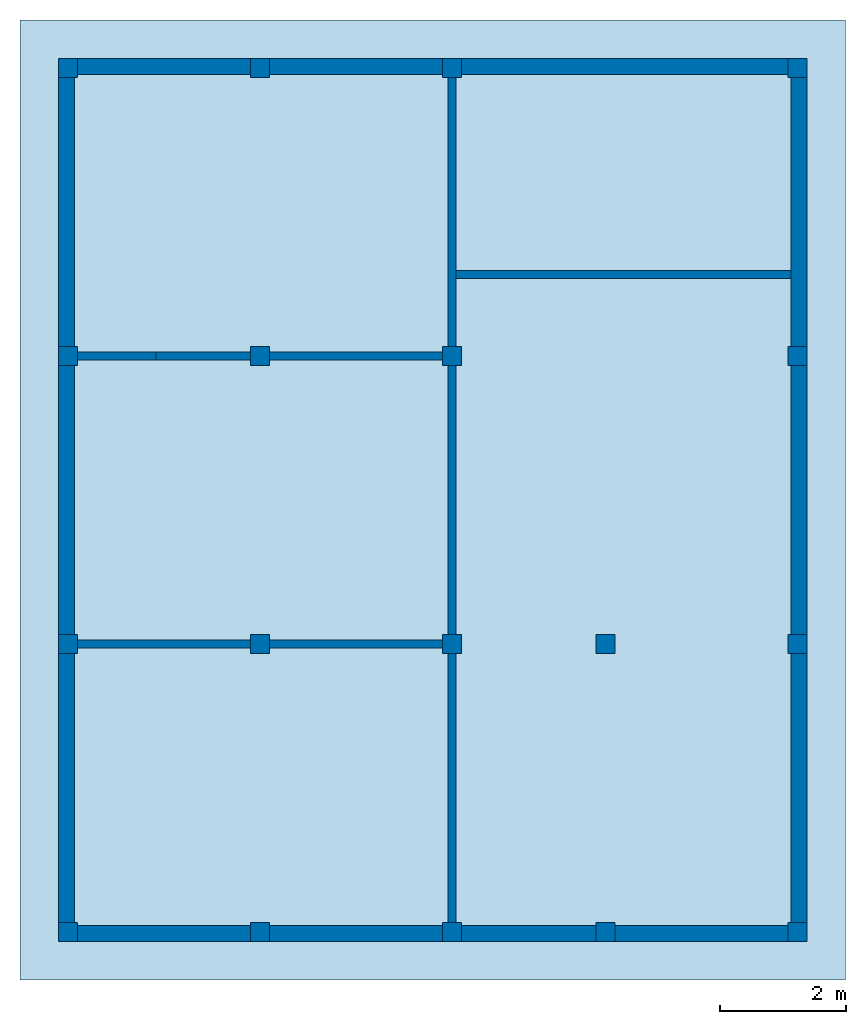
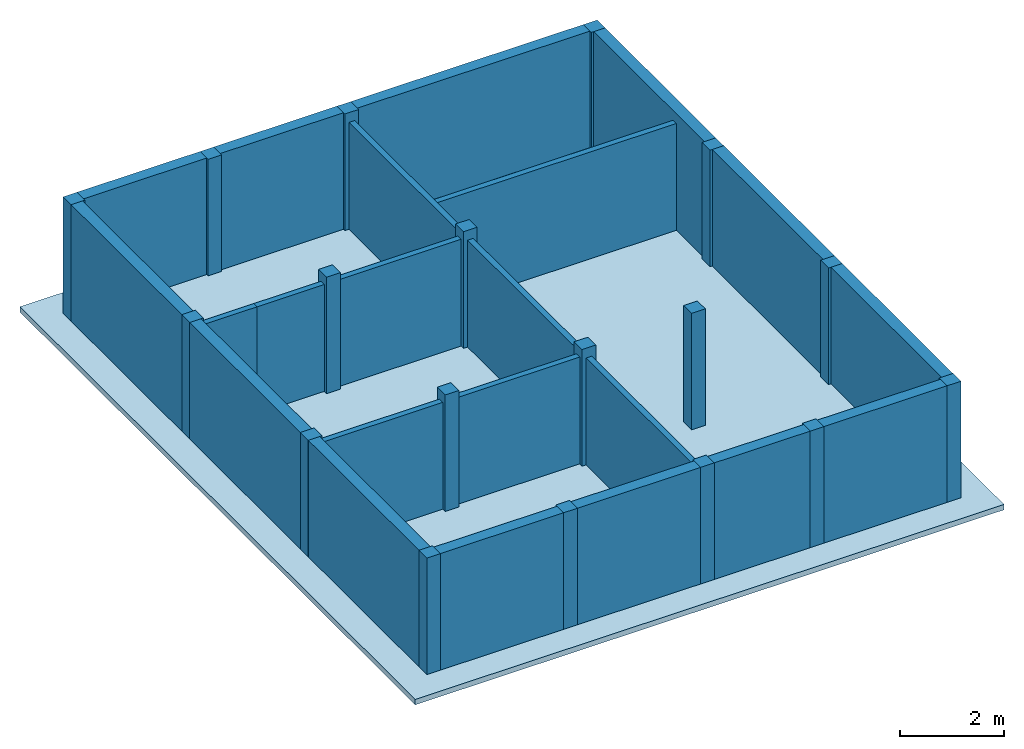
# One storey: 18 columns, 12 walls, 1 slab.
"""IFC2X3 building model written with IfcOpenShell, lengths in feet."""

from ifc_helpers import new_model, entity, si_unit, converted_unit, derived_unit, direction, frame, frame_2d, origin, origin_2d_with_axis, place, context, subcontext, project, spatial, rectangle, extrude, source, transform, mapped, material, layer, layer_set, layer_usage, type_object, type_shapes, element, save


model = new_model("IFC2X3")

# Units and contexts
model_context = context("Model", 3, precision=0.0001, world=origin(), true_north=direction((6.123031769111886e-17, 1.0)))
body_context = subcontext(model_context, "Body", "Model", "MODEL_VIEW")
ifc_project = project(units=[converted_unit("LENGTHUNIT", "FOOT", entity("IfcLengthMeasure", 0.3048), si_unit("LENGTHUNIT", "METRE"), dimensions=[1, 0, 0, 0, 0, 0, 0]), converted_unit("AREAUNIT", "SQUARE FOOT", entity("IfcAreaMeasure", 0.09290304), si_unit("AREAUNIT", "SQUARE_METRE"), dimensions=[2, 0, 0, 0, 0, 0, 0]), converted_unit("VOLUMEUNIT", "CUBIC FOOT", entity("IfcVolumeMeasure", 0.028316846592000004), si_unit("VOLUMEUNIT", "CUBIC_METRE"), dimensions=[3, 0, 0, 0, 0, 0, 0]), converted_unit("PLANEANGLEUNIT", "DEGREE", entity("IfcPlaneAngleMeasure", 0.017453292519943278), si_unit("PLANEANGLEUNIT", "RADIAN"), dimensions=[0, 0, 0, 0, 0, 0, 0]), si_unit("MASSUNIT", "GRAM", prefix="KILO"), derived_unit("MASSDENSITYUNIT", [(si_unit("MASSUNIT", "GRAM", prefix="KILO"), 1), (si_unit("LENGTHUNIT", "METRE"), -3)]), derived_unit("IONCONCENTRATIONUNIT", [(si_unit("MASSUNIT", "GRAM", prefix="KILO"), 1), (si_unit("LENGTHUNIT", "METRE"), -3)]), derived_unit("MOMENTOFINERTIAUNIT", [(si_unit("LENGTHUNIT", "METRE"), 4)]), si_unit("TIMEUNIT", "SECOND"), si_unit("FREQUENCYUNIT", "HERTZ"), si_unit("THERMODYNAMICTEMPERATUREUNIT", "DEGREE_CELSIUS"), derived_unit("THERMALTRANSMITTANCEUNIT", [(si_unit("MASSUNIT", "GRAM", prefix="KILO"), 1), (si_unit("THERMODYNAMICTEMPERATUREUNIT", "KELVIN"), -1), (si_unit("TIMEUNIT", "SECOND"), -3)]), derived_unit("THERMALCONDUCTANCEUNIT", [(si_unit("MASSUNIT", "GRAM", prefix="KILO"), 1), (si_unit("THERMODYNAMICTEMPERATUREUNIT", "KELVIN"), -1), (si_unit("TIMEUNIT", "SECOND"), -3), (si_unit("LENGTHUNIT", "METRE"), 1)]), derived_unit("VOLUMETRICFLOWRATEUNIT", [(si_unit("LENGTHUNIT", "METRE"), 3), (si_unit("TIMEUNIT", "SECOND"), -1)]), derived_unit("MASSFLOWRATEUNIT", [(si_unit("MASSUNIT", "GRAM", prefix="KILO"), 1), (si_unit("TIMEUNIT", "SECOND"), -1)]), derived_unit("ROTATIONALFREQUENCYUNIT", [(si_unit("TIMEUNIT", "SECOND"), -1)]), si_unit("ELECTRICCURRENTUNIT", "AMPERE"), si_unit("ELECTRICVOLTAGEUNIT", "VOLT"), si_unit("POWERUNIT", "WATT"), converted_unit("FORCEUNIT", "KIP", entity("IfcForceMeasure", 2.088543423315013e-05), si_unit("FORCEUNIT", "NEWTON"), dimensions=[1, 1, -2, 0, 0, 0, 0]), si_unit("ILLUMINANCEUNIT", "LUX"), si_unit("LUMINOUSFLUXUNIT", "LUMEN"), si_unit("LUMINOUSINTENSITYUNIT", "CANDELA"), si_unit("ENERGYUNIT", "JOULE"), derived_unit("USERDEFINED", [(si_unit("MASSUNIT", "GRAM", prefix="KILO"), -1), (si_unit("LENGTHUNIT", "METRE"), -2), (si_unit("TIMEUNIT", "SECOND"), 3), (si_unit("LUMINOUSFLUXUNIT", "LUMEN"), 1)]), derived_unit("USERDEFINED", [(si_unit("MASSUNIT", "GRAM", prefix="KILO"), 1), (si_unit("TIMEUNIT", "SECOND"), -3), (si_unit("LENGTHUNIT", "METRE"), 3), (si_unit("ELECTRICCURRENTUNIT", "AMPERE"), -2)]), derived_unit("SOUNDPOWERUNIT", [(si_unit("MASSUNIT", "GRAM", prefix="KILO"), 1), (si_unit("TIMEUNIT", "SECOND"), -3), (si_unit("LENGTHUNIT", "METRE"), 2)]), derived_unit("SOUNDPRESSUREUNIT", [(si_unit("MASSUNIT", "GRAM", prefix="KILO"), 1), (si_unit("LENGTHUNIT", "METRE"), -1), (si_unit("TIMEUNIT", "SECOND"), -2)]), derived_unit("LINEARVELOCITYUNIT", [(si_unit("LENGTHUNIT", "METRE"), 1), (si_unit("TIMEUNIT", "SECOND"), -1)]), si_unit("PRESSUREUNIT", "PASCAL"), derived_unit("USERDEFINED", [(si_unit("MASSUNIT", "GRAM", prefix="KILO"), 1), (si_unit("LENGTHUNIT", "METRE"), -2), (si_unit("TIMEUNIT", "SECOND"), -2)]), derived_unit("LINEARFORCEUNIT", [(si_unit("MASSUNIT", "GRAM", prefix="KILO"), 1), (si_unit("TIMEUNIT", "SECOND"), -2)]), derived_unit("PLANARFORCEUNIT", [(si_unit("MASSUNIT", "GRAM", prefix="KILO"), 1), (si_unit("LENGTHUNIT", "METRE"), -1), (si_unit("TIMEUNIT", "SECOND"), -2)]), derived_unit("SPECIFICHEATCAPACITYUNIT", [(si_unit("THERMODYNAMICTEMPERATUREUNIT", "KELVIN"), -1), (si_unit("LENGTHUNIT", "METRE"), 2), (si_unit("TIMEUNIT", "SECOND"), -2)]), derived_unit("HEATFLUXDENSITYUNIT", [(si_unit("MASSUNIT", "GRAM", prefix="KILO"), 1), (si_unit("TIMEUNIT", "SECOND"), -3)]), derived_unit("HEATINGVALUEUNIT", [(si_unit("LENGTHUNIT", "METRE"), 2), (si_unit("TIMEUNIT", "SECOND"), -2)]), derived_unit("VAPORPERMEABILITYUNIT", [(si_unit("LENGTHUNIT", "METRE"), -1), (si_unit("TIMEUNIT", "SECOND"), 1)]), derived_unit("DYNAMICVISCOSITYUNIT", [(si_unit("MASSUNIT", "GRAM", prefix="KILO"), 1), (si_unit("TIMEUNIT", "SECOND"), -1), (si_unit("LENGTHUNIT", "METRE"), -1)]), derived_unit("THERMALEXPANSIONCOEFFICIENTUNIT", [(si_unit("THERMODYNAMICTEMPERATUREUNIT", "KELVIN"), -1)]), derived_unit("MODULUSOFELASTICITYUNIT", [(si_unit("MASSUNIT", "GRAM", prefix="KILO"), 1), (si_unit("LENGTHUNIT", "METRE"), -1), (si_unit("TIMEUNIT", "SECOND"), -2)]), derived_unit("ISOTHERMALMOISTURECAPACITYUNIT", [(si_unit("LENGTHUNIT", "METRE"), 3), (si_unit("MASSUNIT", "GRAM", prefix="KILO"), -1)]), derived_unit("MOISTUREDIFFUSIVITYUNIT", [(si_unit("TIMEUNIT", "SECOND"), -1), (si_unit("LENGTHUNIT", "METRE"), 2)]), derived_unit("MASSPERLENGTHUNIT", [(si_unit("MASSUNIT", "GRAM", prefix="KILO"), 1), (si_unit("LENGTHUNIT", "METRE"), -1)]), derived_unit("THERMALRESISTANCEUNIT", [(si_unit("MASSUNIT", "GRAM", prefix="KILO"), -1), (si_unit("TIMEUNIT", "SECOND"), 3), (si_unit("THERMODYNAMICTEMPERATUREUNIT", "KELVIN"), 1)]), derived_unit("ACCELERATIONUNIT", [(si_unit("LENGTHUNIT", "METRE"), 1), (si_unit("TIMEUNIT", "SECOND"), -2)]), derived_unit("ANGULARVELOCITYUNIT", [(si_unit("TIMEUNIT", "SECOND"), -1), (si_unit("PLANEANGLEUNIT", "RADIAN"), 1)]), derived_unit("LINEARSTIFFNESSUNIT", [(si_unit("MASSUNIT", "GRAM", prefix="KILO"), 1), (si_unit("TIMEUNIT", "SECOND"), -2)]), derived_unit("WARPINGCONSTANTUNIT", [(si_unit("LENGTHUNIT", "METRE"), 6)]), derived_unit("LINEARMOMENTUNIT", [(si_unit("MASSUNIT", "GRAM", prefix="KILO"), 1), (si_unit("LENGTHUNIT", "METRE"), 1), (si_unit("TIMEUNIT", "SECOND"), -2)]), derived_unit("TORQUEUNIT", [(si_unit("MASSUNIT", "GRAM", prefix="KILO"), 1), (si_unit("LENGTHUNIT", "METRE"), 2), (si_unit("TIMEUNIT", "SECOND"), -2)])], contexts=[model_context])

# Site, building, storey
site_placement = place(None, origin())
site = spatial("IfcSite", under=ifc_project, at=site_placement, CompositionType="ELEMENT")
building_placement = place(site_placement, origin())
building = spatial("IfcBuilding", under=site, at=building_placement, CompositionType="ELEMENT")
storey_placement = place(building_placement, frame((0.0, 0.0, 18.833333333333574)))
storey = spatial("IfcBuildingStorey", under=building, at=storey_placement, Name="Second Floor", CompositionType="ELEMENT", Elevation=18.833333333333574)

# Columns
ifc_material_1 = material(Name="Concrete, Cast-in-Place gray")
column_type = type_object("IfcColumnType", PredefinedType="COLUMN", material=ifc_material_1)
shared_shape = source(origin(), body_context, "Body", "SweptSolid", [
    extrude(rectangle(XDim=0.9999999999999999, YDim=0.9999999999999999, at=origin_2d_with_axis()), frame((0.0, 0.0, 18.833333333333574), z_axis=(0.0, 0.0, 1.0), x_axis=(-1.0, 0.0, 0.0)), (0.0, 0.0, 1.0), 9.00000000000162),
])
type_shapes(column_type, [shared_shape])
for number, where in (
    (1, (9.874478019162162, -49.84124484724893, -18.833333333333574)),
    (2, (29.874478019162154, -49.841244847248994, -18.833333333333574)),
    (3, (37.87447801916216, -49.84124484724902, -18.833333333333574)),
    (4, (47.87447801916217, -49.84124484724906, -18.833333333333574)),
    (5, (19.874478019162158, -49.841244847248966, -18.833333333333574)),
    (6, (9.874478019162186, -34.84124484724893, -18.833333333333574)),
    (7, (29.87447801916219, -34.841244847248994, -18.833333333333574)),
    (8, (37.87447801916219, -34.84124484724902, -18.833333333333574)),
    (9, (47.87447801916219, -34.84124484724906, -18.833333333333574)),
    (10, (19.874478019162183, -34.841244847248966, -18.833333333333574)),
    (11, (9.874478019162211, -19.841244847248934, -18.833333333333574)),
    (12, (29.87447801916221, -19.841244847248998, -18.833333333333574)),
    (13, (47.87447801916221, -19.841244847249058, -18.833333333333574)),
    (14, (19.874478019162204, -19.841244847248966, -18.833333333333574)),
    (15, (9.874478019162234, -4.841244847248884, -18.833333333333574)),
    (16, (29.874478019162233, -4.841244847248948, -18.833333333333574)),
    (17, (47.87447801916224, -4.841244847249006, -18.833333333333574)),
    (18, (19.87447801916223, -4.841244847248915, -18.833333333333574)),
):
    element("IfcColumn", number, at=place(storey_placement, frame(where)), inside=storey, type_object=column_type, material=ifc_material_1, context=body_context, shape_type="MappedRepresentation", body=[
        mapped(shared_shape, transform((0.0, 0.0, 0.0), scale=1.0)),
    ])

# Slab
ifc_material_2 = material(Name="Default Floor")
ifc_layer_1 = layer(ifc_material_2, 0.4166666666666667)
ifc_layer_set_1 = layer_set([ifc_layer_1])
ifc_layer_usage_1 = layer_usage(ifc_layer_set_1, "AXIS3", "POSITIVE", 0.0)
slab_type = type_object("IfcSlabType", PredefinedType="FLOOR", material=ifc_layer_set_1)
slab_placement = place(storey_placement, origin())
element("IfcSlab", 19, at=slab_placement, inside=storey, type_object=slab_type, material=ifc_layer_usage_1, PredefinedType="FLOOR", context=body_context, shape_type="SweptSolid", body=[
    extrude(rectangle(XDim=50.00000000000018, YDim=42.99999999999993, at=origin_2d_with_axis()), frame((28.874478019162204, -27.34124484724897, 0.0), z_axis=(0.0, 0.0, -1.0), x_axis=(0.0, 1.0, 0.0)), (0.0, 0.0, 1.0), 0.41666666666666785),
])

# Walls
ifc_material_3 = material(Name="Pink Paint")
ifc_layer_2 = layer(ifc_material_3, 0.041666666666666664)
ifc_material_4 = material(Name="Default Wall")
ifc_layer_3 = layer(ifc_material_4, 0.75)
ifc_material_5 = material(Name="Gypsum Wall Board")
ifc_layer_4 = layer(ifc_material_5, 0.041666666666666664)
ifc_layer_set_2 = layer_set([ifc_layer_2, ifc_layer_3, ifc_layer_4])
ifc_layer_usage_2 = layer_usage(ifc_layer_set_2, "AXIS2", "NEGATIVE", 0.4166666666666667)
wall_type_1 = type_object("IfcWallType", PredefinedType="STANDARD", material=ifc_layer_set_2)
wall_1_placement = place(storey_placement, frame((9.374478019162236, -4.757911513915549, 0.0)))
element("IfcWallStandardCase", 20, at=wall_1_placement, inside=storey, type_object=wall_type_1, material=ifc_layer_usage_2, context=body_context, shape_type="SweptSolid", body=[
    extrude(rectangle(XDim=38.1666666666666, YDim=0.8333333333333339, at=frame_2d((19.0833333333333, 0.0), x_axis=(-1.0, 0.0))), origin(), (0.0, 0.0, 1.0), 9.00000000000162),
])
wall_2_placement = place(storey_placement, frame((9.791144685828902, -50.34124484724887, 0.0), z_axis=(0.0, 0.0, 1.0), x_axis=(0.0, 1.0, 0.0)))
element("IfcWallStandardCase", 21, at=wall_2_placement, inside=storey, type_object=wall_type_1, material=ifc_layer_usage_2, context=body_context, shape_type="SweptSolid", body=[
    extrude(rectangle(XDim=45.16666666666666, YDim=0.8333333333333321, at=frame_2d((22.58333333333333, 0.0), x_axis=(-1.0, 0.0))), origin(), (0.0, 0.0, 1.0), 9.00000000000162),
])
wall_3_placement = place(storey_placement, frame((48.37447801916217, -49.924578180582216, 0.0), z_axis=(0.0, 0.0, 1.0), x_axis=(-1.0, 0.0, 0.0)))
element("IfcWallStandardCase", 22, at=wall_3_placement, inside=storey, type_object=wall_type_1, material=ifc_layer_usage_2, context=body_context, shape_type="SweptSolid", body=[
    extrude(rectangle(XDim=38.1666666666666, YDim=0.8333333333333286, at=frame_2d((19.0833333333333, 0.0), x_axis=(-1.0, 0.0))), origin(), (0.0, 0.0, 1.0), 9.00000000000162),
])
wall_4_placement = place(storey_placement, frame((47.957811352495504, -4.3412448472488805, 0.0), z_axis=(0.0, 0.0, 1.0), x_axis=(0.0, -1.0, 0.0)))
element("IfcWallStandardCase", 23, at=wall_4_placement, inside=storey, type_object=wall_type_1, material=ifc_layer_usage_2, context=body_context, shape_type="SweptSolid", body=[
    extrude(rectangle(XDim=45.166666666666664, YDim=0.8333333333333286, at=frame_2d((22.583333333333332, 0.0), x_axis=(-1.0, 0.0))), origin(), (0.0, 0.0, 1.0), 9.00000000000162),
])
ifc_material_6 = material(Name="Wood Planks")
ifc_layer_5 = layer(ifc_material_6, 0.4166666666666667)
ifc_layer_set_3 = layer_set([ifc_layer_5])
ifc_layer_usage_3 = layer_usage(ifc_layer_set_3, "AXIS2", "NEGATIVE", 0.20833333333333334)
wall_type_2 = type_object("IfcWallType", PredefinedType="STANDARD", material=ifc_layer_set_3)
wall_5_placement = place(storey_placement, frame((10.37447801916221, -19.841244847248937, 0.0)))
element("IfcWallStandardCase", 24, at=wall_5_placement, inside=storey, type_object=wall_type_2, material=ifc_layer_usage_3, context=body_context, shape_type="SweptSolid", body=[
    extrude(rectangle(XDim=4.083333333333334, YDim=0.4166666666666643, at=frame_2d((2.041666666666667, -6.106226635438361e-16), x_axis=(-1.0, 0.0))), origin(), (0.0, 0.0, 1.0), 8.249999999998622),
])
wall_6_placement = place(storey_placement, frame((29.87447801916221, -19.341244847248994, 0.0), z_axis=(0.0, 0.0, 1.0), x_axis=(0.0, 1.0, 0.0)))
element("IfcWallStandardCase", 25, at=wall_6_placement, inside=storey, type_object=wall_type_2, material=ifc_layer_usage_3, context=body_context, shape_type="SweptSolid", body=[
    extrude(rectangle(XDim=14.000000000000046, YDim=0.4166666666666643, at=frame_2d((7.000000000000023, 0.0), x_axis=(-1.0, 0.0))), origin(), (0.0, 0.0, 1.0), 8.249999999998622),
])
wall_7_placement = place(storey_placement, frame((29.87447801916221, -20.341244847249, 0.0), z_axis=(0.0, 0.0, 1.0), x_axis=(0.0, -1.0, 0.0)))
element("IfcWallStandardCase", 26, at=wall_7_placement, inside=storey, type_object=wall_type_2, material=ifc_layer_usage_3, context=body_context, shape_type="SweptSolid", body=[
    extrude(rectangle(XDim=13.999999999999986, YDim=0.4166666666666643, at=frame_2d((6.999999999999993, 0.0), x_axis=(-1.0, 0.0))), origin(), (0.0, 0.0, 1.0), 8.249999999998622),
])
wall_8_placement = place(storey_placement, frame((29.37447801916219, -34.841244847248994, 0.0), z_axis=(0.0, 0.0, 1.0), x_axis=(-1.0, 0.0, 0.0)))
element("IfcWallStandardCase", 27, at=wall_8_placement, inside=storey, type_object=wall_type_2, material=ifc_layer_usage_3, context=body_context, shape_type="SweptSolid", body=[
    extrude(rectangle(XDim=19.000000000000007, YDim=0.4166666666666714, at=frame_2d((9.500000000000004, 0.0), x_axis=(-1.0, 0.0))), origin(), (0.0, 0.0, 1.0), 8.249999999998622),
])
wall_9_placement = place(storey_placement, frame((29.87447801916219, -35.341244847249, 0.0), z_axis=(0.0, 0.0, 1.0), x_axis=(0.0, -1.0, 0.0)))
element("IfcWallStandardCase", 28, at=wall_9_placement, inside=storey, type_object=wall_type_2, material=ifc_layer_usage_3, context=body_context, shape_type="SweptSolid", body=[
    extrude(rectangle(XDim=13.999999999999986, YDim=0.4166666666666643, at=frame_2d((6.999999999999993, 0.0), x_axis=(-1.0, 0.0))), origin(), (0.0, 0.0, 1.0), 8.249999999998622),
])
wall_10_placement = place(storey_placement, frame((30.082811352495554, -15.591244847248992, 0.0)))
element("IfcWallStandardCase", 29, at=wall_10_placement, inside=storey, type_object=wall_type_2, material=ifc_layer_usage_3, context=body_context, shape_type="SweptSolid", body=[
    extrude(rectangle(XDim=17.45833333333328, YDim=0.41666666666666785, at=frame_2d((8.72916666666664, -1.3877787807814457e-16), x_axis=(-1.0, 0.0))), origin(), (0.0, 0.0, 1.0), 8.249999999998622),
])
wall_11_placement = place(storey_placement, frame((20.374478019162204, -19.84124484724897, 0.0)))
element("IfcWallStandardCase", 30, at=wall_11_placement, inside=storey, type_object=wall_type_2, material=ifc_layer_usage_3, context=body_context, shape_type="SweptSolid", body=[
    extrude(rectangle(XDim=9.000000000000007, YDim=0.4166666666666643, at=frame_2d((4.5000000000000036, 9.71445146547012e-17), x_axis=(-1.0, 0.0))), origin(), (0.0, 0.0, 1.0), 8.249999999998622),
])
wall_12_placement = place(storey_placement, frame((14.457811352495543, -19.84124484724895, 0.0)))
element("IfcWallStandardCase", 31, at=wall_12_placement, inside=storey, type_object=wall_type_2, material=ifc_layer_usage_3, context=body_context, shape_type="SweptSolid", body=[
    extrude(rectangle(XDim=4.916666666666668, YDim=0.4166666666666643, at=frame_2d((2.458333333333334, 7.077671781985373e-16), x_axis=(-1.0, 0.0))), origin(), (0.0, 0.0, 1.0), 8.249999999998622),
])

save(model, "model.ifc")
